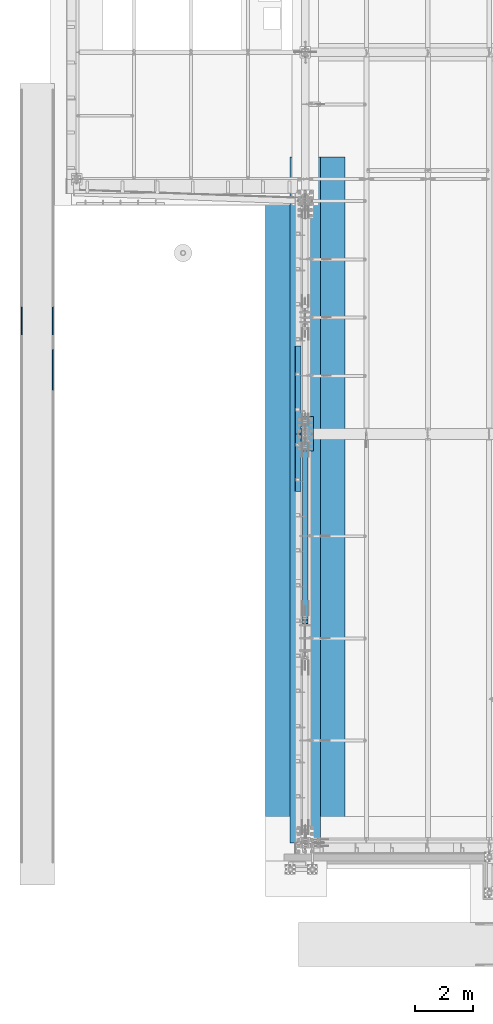
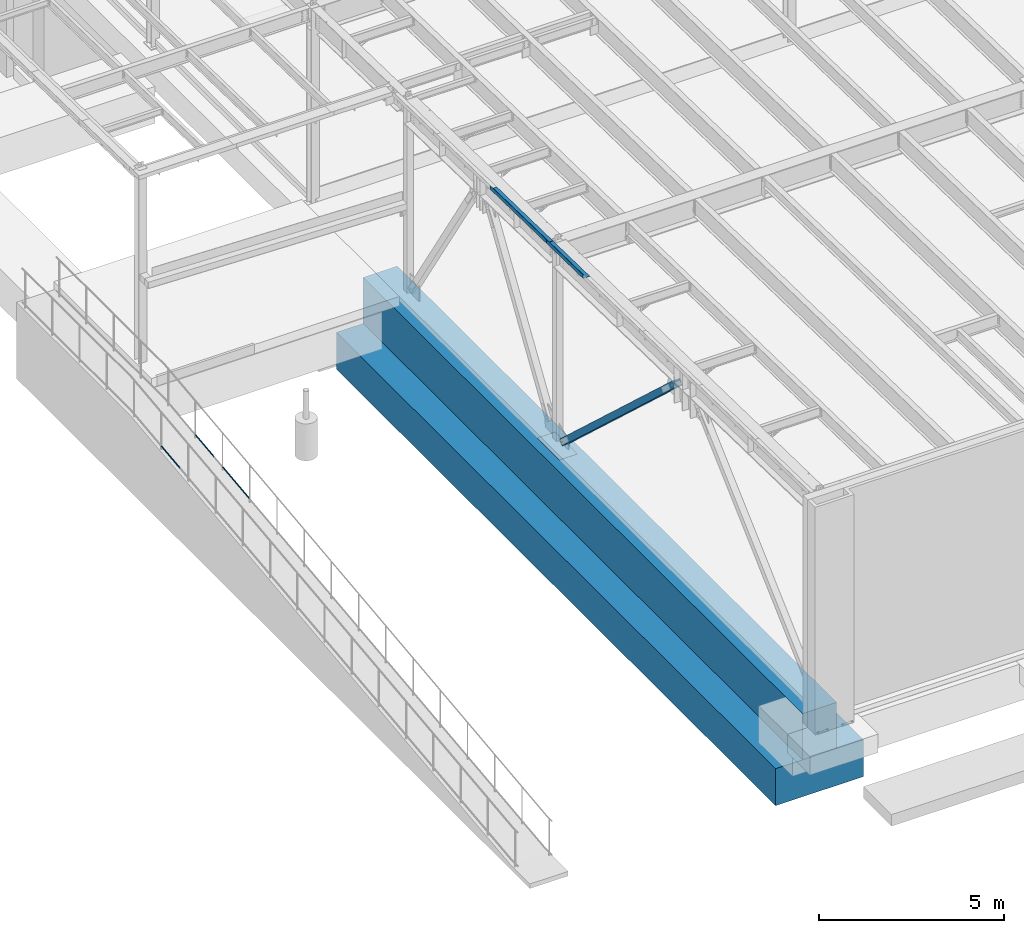
# One storey, part 1043 of 1763: 8 beams, 1 member, 9 elements without a shape of their own.
"""IFC2X3 building model written with IfcOpenShell, lengths in millimetres."""

from ifc_helpers import new_model, si_unit, frame, origin_with_axes, place, context, subcontext, project, spatial, faceted_brep, material, type_object, element, aggregate, save


model = new_model("IFC2X3")

# Units and contexts
model_context = context("Model", 3, precision=1e-05, world=origin_with_axes())
body_context = subcontext(model_context, "Body", "Model", "MODEL_VIEW")
ifc_project = project(units=[si_unit("LENGTHUNIT", "METRE", prefix="MILLI"), si_unit("AREAUNIT", "SQUARE_METRE"), si_unit("VOLUMEUNIT", "CUBIC_METRE"), si_unit("MASSUNIT", "GRAM", prefix="KILO"), si_unit("TIMEUNIT", "SECOND"), si_unit("PLANEANGLEUNIT", "RADIAN"), si_unit("SOLIDANGLEUNIT", "STERADIAN"), si_unit("THERMODYNAMICTEMPERATUREUNIT", "DEGREE_CELSIUS"), si_unit("LUMINOUSINTENSITYUNIT", "LUMEN")], contexts=[model_context])

# Site, building, storey
site_placement = place(None, origin_with_axes())
site = spatial("IfcSite", under=ifc_project, at=site_placement, CompositionType="ELEMENT")
building_placement = place(site_placement, origin_with_axes())
building = spatial("IfcBuilding", under=site, at=building_placement, Name="Undefined", CompositionType="ELEMENT")
storey_placement = place(building_placement, origin_with_axes())
storey = spatial("IfcBuildingStorey", under=building, at=storey_placement, Name="Undefined", CompositionType="ELEMENT", Elevation=0.0)

# Assembly, beam
assembly_1_placement = place(storey_placement, origin_with_axes())
assembly_1 = element("IfcElementAssembly", 1, at=assembly_1_placement, inside=storey, Name="GUARDRAIL", AssemblyPlace="NOTDEFINED", PredefinedType="RIGID_FRAME")
ifc_material_1 = material(Name="STEEL/A513")
beam_type_1 = type_object("IfcBeamType", PredefinedType="NOTDEFINED")
beam_1_placement = place(assembly_1_placement, frame((-97200.6527017878, 3879.70609643673, 5728.63484161927), z_axis=(0.0, -0.114062593029902, 0.993473565260443), x_axis=(0.0, 0.993473565260443, 0.114062593029902)))
beam_1 = element("IfcBeam", 2, at=beam_1_placement, type_object=beam_type_1, material=ifc_material_1, Name="GUARDRAIL", context=body_context, shape_type="Brep", body=[
    faceted_brep([(1007.89445682054, -9.52499999999418, 16.4977839423982), (1007.31680569548, -9.52499999999418, 11.466712380261), (1007.03157048926, -7.68349999999919, 13.3082123802606), (1005.19564016486, 0.0, 15.367000000304), (1005.61851013745, 0.0, 19.0500000003049), (1007.03157048927, 7.68349999999919, 13.3082123802606), (1007.31680569548, 9.52499999999418, 11.466712380261), (1007.89445682054, 9.52499999999418, 16.4977839423982), (1022.60640745074, 19.0500000000029, 3.08318703901023e-10), (1014.11245879407, 16.4977839420899, 9.52500000030705), (1011.92520031513, 16.4977839420899, -9.52499999969496), (1010.6904972139, 13.3082123799541, 7.68350000030568), (1011.8806165228, 15.3669999999984, 3.06499714497477e-10), (1008.92610870756, 13.3082123799541, -7.68349999969541), (1004.6836651308, 9.52499999999418, -11.4667123796526), (1004.10601400574, 9.52499999999418, -16.4977839417907), (1003.975559952, 7.68349999999919, -13.308212379653), (1001.66686315217, 0.0, -15.3669999996973), (1001.24399317958, 0.0, -19.0499999996982), (1004.6836651308, -9.52499999999418, -11.4667123796526), (1004.10601400574, -9.52499999999418, -16.4977839417907), (1003.975559952, -7.68349999999919, -13.308212379653), (1022.60640745069, -19.0500000000029, 3.14685166813433e-10), (1011.92520031513, -16.4977839420899, -9.52499999969496), (1014.11245879407, -16.4977839420899, 9.52500000030705), (1008.92610870756, -13.3082123799541, -7.68349999969541), (1011.88061652279, -15.3669999999984, 3.06499714497477e-10), (1010.69049721389, -13.3082123799541, 7.68350000030568), (0.0, -16.4977839420899, -9.52500000000146), (0.0, -9.52499999999418, -16.4977839420935), (1.45519152283669e-11, 1.81898940354586e-12, -19.0499999999993), (0.0, 9.52499999999418, -16.4977839420935), (0.0, 16.4977839420899, -9.52500000000146), (0.0, 19.0500000000029, 0.0), (0.0, 16.4977839420899, 9.52500000000146), (0.0, 9.52499999999418, 16.4977839420935), (1.45519152283669e-11, 1.81898940354586e-12, 19.0499999999993), (0.0, -9.52499999999418, 16.4977839420935), (0.0, -16.4977839420899, 9.52500000000146), (0.0, -19.0500000000029, 0.0), (3.63797880709171e-12, -13.3082123799541, -7.68349999999737), (3.63797880709171e-12, -7.68349999999919, -13.3082123799522), (3.63797880709171e-12, 0.0, -15.3669999999956), (3.63797880709171e-12, 7.68349999999919, -13.3082123799522), (3.63797880709171e-12, 13.3082123799541, -7.68349999999737), (4.71409293822944e-08, 15.3669999999984, 0.0), (-1.81898940354586e-12, 13.3082123799541, 7.68349999999919), (-3.63797880709171e-12, 7.68349999999919, 13.3082123799531), (-1.81898940354586e-12, 0.0, 15.3669999999966), (-3.63797880709171e-12, -7.68349999999919, 13.3082123799531), (-1.81898940354586e-12, -13.3082123799541, 7.68349999999919), (4.71409293822944e-08, -15.3669999999984, 0.0)], [[[0, 1, 2, 3, 4]], [[4, 3, 5, 6, 7]], [[8, 9, 10]], [[7, 6, 11, 12, 13, 14, 15, 10, 9]], [[16, 17, 18, 15, 14]], [[19, 20, 18, 17, 21]], [[22, 23, 24]], [[24, 23, 20, 19, 25, 26, 27, 1, 0]], [[28, 29, 20, 23]], [[29, 30, 18, 20]], [[30, 31, 15, 18]], [[31, 32, 10, 15]], [[32, 33, 8, 10]], [[33, 34, 9, 8]], [[34, 35, 7, 9]], [[35, 36, 4, 7]], [[36, 37, 0, 4]], [[37, 38, 24, 0]], [[38, 39, 22, 24]], [[39, 28, 23, 22]], [[38, 37, 36, 35, 34, 33, 32, 31, 30, 29, 28, 39], [40, 41, 42, 43, 44, 45, 46, 47, 48, 49, 50, 51]], [[40, 51, 26, 25]], [[21, 41, 40, 25, 19]], [[42, 41, 21, 17]], [[43, 42, 17, 16]], [[44, 43, 16, 14, 13]], [[45, 44, 13, 12]], [[46, 45, 12, 11]], [[5, 47, 46, 11, 6]], [[48, 47, 5, 3]], [[49, 48, 3, 2]], [[50, 49, 2, 1, 27]], [[51, 50, 27, 26]]]),
])
aggregate(assembly_1, [beam_1])

assembly_2_placement = place(storey_placement, origin_with_axes())
assembly_2 = element("IfcElementAssembly", 3, at=assembly_2_placement, inside=storey, Name="GUARDRAIL", AssemblyPlace="NOTDEFINED", PredefinedType="RIGID_FRAME")
beam_2_placement = place(assembly_2_placement, frame((-96133.8527017878, 3879.70609643673, 5728.63484161927), z_axis=(0.0, -0.114062593029902, 0.993473565260443), x_axis=(0.0, 0.993473565260443, 0.114062593029902)))
beam_2 = element("IfcBeam", 4, at=beam_2_placement, type_object=beam_type_1, material=ifc_material_1, Name="GUARDRAIL", context=body_context, shape_type="Brep", body=[
    faceted_brep([(1007.89445682054, -9.52499999999418, 16.4977839423982), (1007.31680569548, -9.52499999999418, 11.466712380261), (1007.03157048926, -7.68349999999919, 13.3082123802606), (1005.19564016486, 0.0, 15.367000000304), (1005.61851013745, 0.0, 19.0500000003049), (1007.03157048927, 7.68349999999919, 13.3082123802606), (1007.31680569548, 9.52499999999418, 11.466712380261), (1007.89445682054, 9.52499999999418, 16.4977839423982), (1022.60640745074, 19.0500000000029, 3.08318703901023e-10), (1014.11245879407, 16.4977839420899, 9.52500000030705), (1011.92520031513, 16.4977839420899, -9.52499999969496), (1010.6904972139, 13.3082123799541, 7.68350000030568), (1011.8806165228, 15.3669999999984, 3.06499714497477e-10), (1008.92610870756, 13.3082123799541, -7.68349999969541), (1004.6836651308, 9.52499999999418, -11.4667123796526), (1004.10601400574, 9.52499999999418, -16.4977839417907), (1003.975559952, 7.68349999999919, -13.308212379653), (1001.66686315217, 0.0, -15.3669999996973), (1001.24399317958, 0.0, -19.0499999996982), (1004.6836651308, -9.52499999999418, -11.4667123796526), (1004.10601400574, -9.52499999999418, -16.4977839417907), (1003.975559952, -7.68349999999919, -13.308212379653), (1022.60640745069, -19.0500000000029, 3.14685166813433e-10), (1011.92520031513, -16.4977839420899, -9.52499999969496), (1014.11245879407, -16.4977839420899, 9.52500000030705), (1008.92610870756, -13.3082123799541, -7.68349999969541), (1011.88061652279, -15.3669999999984, 3.06499714497477e-10), (1010.69049721389, -13.3082123799541, 7.68350000030568), (0.0, -16.4977839420899, -9.52500000000146), (0.0, -9.52499999999418, -16.4977839420935), (1.45519152283669e-11, 1.81898940354586e-12, -19.0499999999993), (0.0, 9.52499999999418, -16.4977839420935), (0.0, 16.4977839420899, -9.52500000000146), (0.0, 19.0500000000029, 0.0), (0.0, 16.4977839420899, 9.52500000000146), (0.0, 9.52499999999418, 16.4977839420935), (1.45519152283669e-11, 1.81898940354586e-12, 19.0499999999993), (0.0, -9.52499999999418, 16.4977839420935), (0.0, -16.4977839420899, 9.52500000000146), (0.0, -19.0500000000029, 0.0), (3.63797880709171e-12, -13.3082123799541, -7.68349999999737), (3.63797880709171e-12, -7.68349999999919, -13.3082123799522), (3.63797880709171e-12, 0.0, -15.3669999999956), (3.63797880709171e-12, 7.68349999999919, -13.3082123799522), (3.63797880709171e-12, 13.3082123799541, -7.68349999999737), (4.71409293822944e-08, 15.3669999999984, 0.0), (-1.81898940354586e-12, 13.3082123799541, 7.68349999999919), (-3.63797880709171e-12, 7.68349999999919, 13.3082123799531), (-1.81898940354586e-12, 0.0, 15.3669999999966), (-3.63797880709171e-12, -7.68349999999919, 13.3082123799531), (-1.81898940354586e-12, -13.3082123799541, 7.68349999999919), (4.71409293822944e-08, -15.3669999999984, 0.0)], [[[0, 1, 2, 3, 4]], [[4, 3, 5, 6, 7]], [[8, 9, 10]], [[7, 6, 11, 12, 13, 14, 15, 10, 9]], [[16, 17, 18, 15, 14]], [[19, 20, 18, 17, 21]], [[22, 23, 24]], [[24, 23, 20, 19, 25, 26, 27, 1, 0]], [[28, 29, 20, 23]], [[29, 30, 18, 20]], [[30, 31, 15, 18]], [[31, 32, 10, 15]], [[32, 33, 8, 10]], [[33, 34, 9, 8]], [[34, 35, 7, 9]], [[35, 36, 4, 7]], [[36, 37, 0, 4]], [[37, 38, 24, 0]], [[38, 39, 22, 24]], [[39, 28, 23, 22]], [[38, 37, 36, 35, 34, 33, 32, 31, 30, 29, 28, 39], [40, 41, 42, 43, 44, 45, 46, 47, 48, 49, 50, 51]], [[40, 51, 26, 25]], [[21, 41, 40, 25, 19]], [[42, 41, 21, 17]], [[43, 42, 17, 16]], [[44, 43, 16, 14, 13]], [[45, 44, 13, 12]], [[46, 45, 12, 11]], [[5, 47, 46, 11, 6]], [[48, 47, 5, 3]], [[49, 48, 3, 2]], [[50, 49, 2, 1, 27]], [[51, 50, 27, 26]]]),
])
aggregate(assembly_2, [beam_2])

assembly_3_placement = place(storey_placement, origin_with_axes())
assembly_3 = element("IfcElementAssembly", 5, at=assembly_3_placement, inside=storey, Name="GUARDRAIL", AssemblyPlace="NOTDEFINED", PredefinedType="RIGID_FRAME")
beam_3_placement = place(assembly_3_placement, frame((-96133.8527017878, 1949.23787684902, 5506.99410694077), z_axis=(0.0, -0.114062593029902, 0.993473565260443), x_axis=(0.0, 0.993473565260443, 0.114062593029902)))
beam_3 = element("IfcBeam", 6, at=beam_3_placement, type_object=beam_type_1, material=ifc_material_1, Name="GUARDRAIL", context=body_context, shape_type="Brep", body=[
    faceted_brep([(1468.16675315117, -9.52499999999418, 16.4977839425374), (1467.58910193435, -9.52499999999418, 11.4667123803993), (1467.30386676072, -7.68349999999919, 13.3082123803997), (1465.46793646955, 0.0, 15.3670000004431), (1465.89080650931, 0.0, 19.0500000004431), (1467.30386676072, 7.68349999999919, 13.3082123803997), (1467.58910193435, 9.52499999999418, 11.4667123803993), (1468.16675315117, 9.52499999999418, 16.4977839425374), (1482.87870351455, 19.0500000000029, 4.47471393272281e-10), (1474.38475501203, 16.4977839420899, 9.52500000044529), (1472.19749618567, 16.4977839420899, -9.52499999955671), (1470.96279339167, 13.3082123799541, 7.68350000044484), (1472.15291256472, 15.3669999999984, 4.43833414465189e-10), (1469.19840460508, 13.3082123799541, -7.68349999955717), (1464.95596095143, 9.52499999999418, -11.4667123795143), (1464.37830973461, 9.52499999999418, -16.4977839416533), (1464.24785573805, 7.68349999999919, -13.3082123795139), (1461.93915889636, 0.0, -15.3669999995591), (1461.5162888566, 0.0, -19.04999999956), (1464.95596095143, -9.52499999999418, -11.4667123795143), (1464.37830973461, -9.52499999999418, -16.4977839416533), (1464.24785573805, -7.68349999999919, -13.3082123795139), (1482.87870351475, -19.0500000000029, 4.2564352042973e-10), (1472.19749618567, -16.4977839420899, -9.52499999955671), (1474.38475501203, -16.4977839420899, 9.52500000044529), (1469.19840460508, -13.3082123799541, -7.68349999955717), (1472.15291256472, -15.3669999999984, 4.43833414465189e-10), (1470.96279339167, -13.3082123799541, 7.68350000044484), (8.49524500772077, -16.4977839420899, -9.52499999999782), (14.7132496349991, -9.52499999999418, -16.4977839420899), (0.00129272617550669, 19.0500000000029, 0.0), (8.49524500772077, 16.4977839420899, -9.52499999999782), (10.6824953029745, 16.4977839420899, 9.52500000000418), (18.5016782752491, 9.52499999999418, 16.4977839421008), (21.3636978799404, 0.0, 19.0500000000075), (14.7132496349991, 9.52499999999418, -16.4977839420899), (16.989197289432, 0.0, -19.0499999999956), (17.4120656798477, 0.0, -15.3669999999956), (15.2908985987647, -9.52499999999418, -11.4667123799509), (15.5761345719984, -7.68349999999919, -13.3082123799513), (15.5761345719984, 7.68349999999919, -13.3082123799513), (15.2908985987647, 9.52499999999418, -11.4667123799509), (11.9172056406151, 13.3082123799541, -7.68349999999737), (10.7270831318519, 15.3669999999984, 4.54747350886464e-12), (13.6815875454467, 13.3082123799541, 7.68350000000555), (17.9240293114835, 9.52499999999418, 11.4667123799618), (18.6321336751216, 7.68349999999919, 13.3082123799622), (20.9408294895247, 0.0, 15.3670000000075), (18.6321336751212, -7.68349999999919, 13.3082123799622), (17.9240293114835, -9.52499999999418, 11.4667123799618), (18.5016782752491, -9.52499999999418, 16.4977839421008), (10.6824953029745, -16.4977839420899, 9.52500000000418), (0.00129272617550669, -19.0500000000029, 0.0), (13.6815875454458, -13.3082123799541, 7.68350000000464), (10.7270831318501, -15.3669999999984, 3.63797880709171e-12), (11.9172056406137, -13.3082123799541, -7.68349999999646)], [[[0, 1, 2, 3, 4]], [[4, 3, 5, 6, 7]], [[8, 9, 10]], [[7, 6, 11, 12, 13, 14, 15, 10, 9]], [[16, 17, 18, 15, 14]], [[19, 20, 18, 17, 21]], [[22, 23, 24]], [[24, 23, 20, 19, 25, 26, 27, 1, 0]], [[28, 29, 20, 23]], [[30, 31, 32]], [[33, 34, 4, 7]], [[32, 33, 7, 9]], [[30, 32, 9, 8]], [[31, 30, 8, 10]], [[35, 31, 10, 15]], [[36, 35, 15, 18]], [[29, 36, 18, 20]], [[37, 36, 29, 38, 39]], [[40, 41, 35, 36, 37]], [[32, 31, 35, 41, 42, 43, 44, 45, 33]], [[33, 45, 46, 47, 34]], [[34, 47, 48, 49, 50]], [[34, 50, 0, 4]], [[50, 51, 24, 0]], [[51, 52, 22, 24]], [[52, 28, 23, 22]], [[51, 28, 52]], [[50, 49, 53, 54, 55, 38, 29, 28, 51]], [[55, 54, 26, 25]], [[21, 39, 38, 55, 25, 19]], [[37, 39, 21, 17]], [[40, 37, 17, 16]], [[42, 41, 40, 16, 14, 13]], [[43, 42, 13, 12]], [[44, 43, 12, 11]], [[5, 46, 45, 44, 11, 6]], [[47, 46, 5, 3]], [[48, 47, 3, 2]], [[53, 49, 48, 2, 1, 27]], [[54, 53, 27, 26]]]),
])
aggregate(assembly_3, [beam_3])

assembly_4_placement = place(storey_placement, origin_with_axes())
assembly_4 = element("IfcElementAssembly", 7, at=assembly_4_placement, inside=storey, Name="STRIP FOOTING", AssemblyPlace="NOTDEFINED", PredefinedType="REINFORCEMENT_UNIT")
ifc_material_2 = material(Name="CONCRETE/5000")
beam_type_2 = type_object("IfcBeamType", PredefinedType="NOTDEFINED")
beam_4_placement = place(assembly_4_placement, frame((-87375.4372736983, -13716.0, 4267.2), z_axis=(0.0, 0.0, 1.0), x_axis=(0.0, 1.0, 0.0)))
beam_4 = element("IfcBeam", 8, at=beam_4_placement, type_object=beam_type_2, material=ifc_material_2, Name="STRIP FOOTING", context=body_context, shape_type="Brep", body=[
    faceted_brep([(0.0, 533.399999999994, -762.0), (0.0, 533.399999999994, 762.0), (23774.4, 533.399999999994, 762.0), (23774.4, 533.399999999994, -762.0), (0.0, -533.399999999994, 762.0), (23774.4, -533.399999999994, 762.0), (0.0, -533.399999999994, -762.0), (23774.4, -533.399999999994, -762.0)], [[[0, 1, 2, 3]], [[1, 4, 5, 2]], [[4, 6, 7, 5]], [[6, 0, 3, 7]], [[5, 7, 3, 2]], [[6, 4, 1, 0]]]),
])
aggregate(assembly_4, [beam_4])

assembly_5_placement = place(storey_placement, origin_with_axes())
assembly_5 = element("IfcElementAssembly", 9, at=assembly_5_placement, inside=storey, Name="BEAM", AssemblyPlace="NOTDEFINED", PredefinedType="RIGID_FRAME")
ifc_material_3 = material(Name="STEEL/A36")
beam_type_3 = type_object("IfcBeamType", PredefinedType="NOTDEFINED")
beam_5_placement = place(assembly_5_placement, frame((-87515.1372736983, 1990.4813218811, 11879.5172039282), z_axis=(0.0, -0.999781542838788, 0.0209013539966307), x_axis=(-1.0, 0.0, 0.0)))
beam_5 = element("IfcBeam", 10, at=beam_5_placement, type_object=beam_type_3, material=ifc_material_3, Name="BENT_PLATE", context=body_context, shape_type="Brep", body=[
    faceted_brep([(0.0, -3.17499999999927, -1523.99999999999), (0.0, -3.17499999999927, 1524.0), (0.0, 3.17499999999927, 1524.0), (0.0, 3.17499999999927, -1523.99999999999), (209.549987792998, 3.174999999379, 1523.99999999984), (209.549987793027, 3.17500000043947, -1523.99999999984), (203.199987793021, -3.17499999956271, -1523.99999999984), (203.199987792992, -3.17500000062137, 1523.99999999984), (209.549987793012, -123.825003589356, 1523.99999999986), (209.549987793012, -123.825003588337, -1523.99999999982), (203.199987793007, -123.825003589356, 1523.99999999986), (203.199987793007, -123.825003588337, -1523.99999999982)], [[[0, 1, 2, 3]], [[3, 2, 4, 5]], [[1, 0, 6, 7]], [[5, 4, 8, 9]], [[4, 2, 1, 7, 10, 8]], [[7, 6, 11, 10]], [[6, 0, 3, 5, 9, 11]], [[10, 11, 9, 8]]]),
])
aggregate(assembly_5, [beam_5])

assembly_6_placement = place(storey_placement, origin_with_axes())
assembly_6 = element("IfcElementAssembly", 11, at=assembly_6_placement, inside=storey, Name="BEAM", AssemblyPlace="NOTDEFINED", PredefinedType="RIGID_FRAME")
beam_type_4 = type_object("IfcBeamType", PredefinedType="NOTDEFINED")
beam_6_placement = place(assembly_6_placement, frame((-87516.7242736983, -534.372399278056, 11932.3016027582), z_axis=(0.0, -0.999781542838788, 0.0209013539966307), x_axis=(-1.0, 0.0, 0.0)))
beam_6 = element("IfcBeam", 12, at=beam_6_placement, type_object=beam_type_4, material=ifc_material_3, Name="BENT_PLATE", context=body_context, shape_type="Brep", body=[
    faceted_brep([(3.63797880709171e-10, -3.17499999965912, -998.766500000008), (-4.07453626394272e-10, -3.17500000034852, 998.766500000008), (-3.63797880709171e-10, 3.1749999996573, 998.766500000008), (4.07453626394272e-10, 3.1750000003467, -998.766500000008), (207.962982177429, 3.17499999825122, 998.766500000088), (207.962982179466, 3.17499999894244, -998.766499999928), (201.61298217946, -3.17500000102154, -998.76649999993), (201.612982177423, -3.17500000171094, 998.766500000086), (207.962982178098, -123.825003589211, 998.766500000169), (207.962982178782, -123.825003589796, -998.766499999847), (201.612982178107, -123.825003589211, 998.766500000167), (201.612982178791, -123.825003589796, -998.76649999985)], [[[0, 1, 2, 3]], [[3, 2, 4, 5]], [[1, 0, 6, 7]], [[5, 4, 8, 9]], [[4, 2, 1, 7, 10, 8]], [[7, 6, 11, 10]], [[6, 0, 3, 5, 9, 11]], [[10, 11, 9, 8]]]),
])
aggregate(assembly_6, [beam_6])

assembly_7_placement = place(storey_placement, origin_with_axes())
assembly_7 = element("IfcElementAssembly", 13, at=assembly_7_placement, inside=storey, Name="STRIP FOOTING", AssemblyPlace="NOTDEFINED", PredefinedType="REINFORCEMENT_UNIT")
beam_type_5 = type_object("IfcBeamType", PredefinedType="NOTDEFINED")
beam_7_placement = place(assembly_7_placement, frame((-87375.4372736983, -13716.0, 2895.6), z_axis=(0.0, 0.0, 1.0), x_axis=(0.0, 1.0, 0.0)))
beam_7 = element("IfcBeam", 14, at=beam_7_placement, type_object=beam_type_5, material=ifc_material_2, Name="STRIP FOOTING", context=body_context, shape_type="Brep", body=[
    faceted_brep([(0.0, 1371.6, -609.6), (0.0, 1371.6, 609.6), (23774.4, 1371.60000000001, 609.6), (23774.4, 1371.60000000001, -609.6), (0.0, -1371.6, 609.6), (23774.4, -1371.60000000001, 609.6), (0.0, -1371.6, -609.6), (23774.4, -1371.60000000001, -609.6)], [[[0, 1, 2, 3]], [[1, 4, 5, 2]], [[4, 6, 7, 5]], [[6, 0, 3, 7]], [[5, 7, 3, 2]], [[6, 4, 1, 0]]]),
])
aggregate(assembly_7, [beam_7])

assembly_8_placement = place(storey_placement, origin_with_axes())
assembly_8 = element("IfcElementAssembly", 15, at=assembly_8_placement, inside=storey, Name="TEMPLATE", AssemblyPlace="NOTDEFINED", PredefinedType="RIGID_FRAME")
beam_type_6 = type_object("IfcBeamType", PredefinedType="NOTDEFINED")
beam_8_placement = place(assembly_8_placement, frame((-87375.4372736983, -126.999999999999, 5083.175), z_axis=(-1.0, 0.0, 0.0), x_axis=(0.0, 1.0, 0.0)))
beam_8 = element("IfcBeam", 16, at=beam_8_placement, type_object=beam_type_6, material=ifc_material_3, Name="TEMPLATE", context=body_context, shape_type="Brep", body=[
    faceted_brep([(0.0, 3.17500000000018, -279.399999999994), (0.0, 3.17500000000018, 279.399999999994), (1193.8, 3.17500000000018, 279.399999999994), (1193.8, 3.17500000000018, -279.399999999994), (0.0, -3.17500000000018, 279.399999999994), (1193.8, -3.17500000000018, 279.399999999994), (0.0, -3.17500000000018, -279.399999999994), (1193.8, -3.17500000000018, -279.399999999994)], [[[0, 1, 2, 3]], [[1, 4, 5, 2]], [[4, 6, 7, 5]], [[6, 0, 3, 7]], [[5, 7, 3, 2]], [[6, 4, 1, 0]]]),
])
aggregate(assembly_8, [beam_8])

# Assembly, member
assembly_9_placement = place(storey_placement, origin_with_axes())
assembly_9 = element("IfcElementAssembly", 17, at=assembly_9_placement, inside=storey, Name="V. BRACE", AssemblyPlace="NOTDEFINED", PredefinedType="RIGID_FRAME")
ifc_material_4 = material()
member_type = type_object("IfcMemberType", Name="HSS8X8X1/2", PredefinedType="NOTDEFINED")
member_placement = place(assembly_9_placement, frame((-87375.4372736983, 457.200000000009, 5130.79999999998), z_axis=(0.0, 0.677746873297468, 0.735295298322726), x_axis=(0.0, -0.735295298322726, 0.677746873297467)))
member = element("IfcMember", 18, at=member_placement, type_object=member_type, material=ifc_material_4, Name="V. BRACE", ObjectType="HSS8X8X1/2", context=body_context, shape_type="Brep", body=[
    faceted_brep([(8851.58529904641, 11.1124999999884, 101.599999997602), (8216.58531363784, 11.1124999999884, 101.599999997773), (8216.58531363785, 11.1124999999884, 88.8999999977718), (8851.58529904641, 11.1124999999884, 88.899999997599), (8212.94025409054, 10.387452576193, 101.599999997774), (8212.94025409055, 10.387452576193, 88.8999999977736), (8209.85012181678, 8.32269220252056, 101.599999997775), (8209.85012181679, 8.32269220252056, 88.8999999977736), (8207.7853614431, 5.23255992875784, 101.599999997774), (8207.78536144311, 5.23255992875784, 88.8999999977755), (8207.06031401931, 1.58750038145809, 101.599999997774), (8207.06031401932, 1.58750038145809, 88.8999999977755), (8207.06031401931, -1.58750076295109, 101.599999997774), (8207.06031401932, -1.58750076295109, 88.8999999977755), (8207.7853614431, -5.23256031025085, 101.599999997774), (8207.78536144311, -5.23256031025085, 88.8999999977755), (8209.85012181678, -8.32269258401357, 101.599999997775), (8209.85012181679, -8.32269258401357, 88.8999999977736), (8212.94025409054, -10.387452957686, 101.599999997774), (8212.94025409055, -10.387452957686, 88.8999999977736), (8216.58531363784, -11.1125003814814, 101.599999997773), (8216.58531363785, -11.1125003814814, 88.8999999977718), (8851.58529904641, -11.1125003814814, 101.599999997602), (8851.58529904641, -11.1125003814814, 88.899999997599), (8851.58529904644, 11.1124999999884, -88.9000000024148), (8216.58531363792, 11.1124999999884, -88.9000000022429), (8216.58531363793, 11.1124999999884, -101.600000002245), (8851.58529904644, 11.1124999999884, -101.600000002417), (8212.94025409063, 10.387452576193, -88.9000000022425), (8212.94025409064, 10.387452576193, -101.600000002241), (8209.85012181686, 8.32269220252056, -88.9000000022397), (8209.85012181687, 8.32269220252056, -101.600000002242), (8207.78536144319, 5.23255992875784, -88.9000000022411), (8207.78536144319, 5.23255992875784, -101.600000002241), (8207.06031401939, 1.58750038145809, -88.9000000022411), (8207.0603140194, 1.58750038145809, -101.60000000224), (8207.06031401939, -1.58750076295109, -88.9000000022411), (8207.0603140194, -1.58750076295109, -101.60000000224), (8207.78536144319, -5.23256031025085, -88.9000000022411), (8207.78536144319, -5.23256031025085, -101.600000002241), (8209.85012181686, -8.32269258401357, -88.9000000022397), (8209.85012181687, -8.32269258401357, -101.600000002242), (8212.94025409063, -10.387452957686, -88.9000000022425), (8212.94025409064, -10.387452957686, -101.600000002241), (8216.58531363792, -11.1125003814814, -88.9000000022429), (8216.58531363793, -11.1125003814814, -101.600000002245), (8851.58529904644, -11.1125003814814, -88.9000000024148), (8851.58529904644, -11.1125003814814, -101.600000002417), (484.966364630503, 88.8999999999942, 88.9000000001724), (484.966364630512, 88.8999999999942, -88.8999999999123), (8851.58529904644, 88.8999999999942, -88.9000000024148), (8851.58529904641, 88.8999999999942, 88.899999997599), (8851.58529904641, -88.8999999999942, 88.899999997599), (484.966364630503, -88.8999999999942, 88.9000000001724), (484.966364630503, -14.2874999999913, 88.9000000001724), (713.566372206521, -14.2874999999913, 88.9000000002343), (718.426451724556, -13.3207700774074, 88.9000000002343), (722.546628192698, -10.5677561769262, 88.9000000002343), (725.29964209317, -6.44757970876526, 88.9000000002361), (726.266372015754, -1.58750019072613, 88.9000000002379), (726.266372015754, 1.58750095368305, 88.9000000002379), (725.29964209317, 6.44758047172218, 88.9000000002361), (722.546628192698, 10.5677569398831, 88.9000000002343), (718.426451724556, 13.3207708403643, 88.9000000002343), (713.566372206521, 14.2875007629482, 88.9000000002343), (484.966364630503, 14.2875007629482, 88.9000000001724), (484.966364630512, -88.8999999999942, -88.8999999999123), (8851.58529904644, -88.8999999999942, -88.9000000024148), (484.966364630512, 14.2875007629482, -88.8999999999123), (713.566372206587, 14.2875007629482, -88.8999999998487), (718.426451724621, 13.3207708403643, -88.8999999998487), (722.546628192766, 10.5677569398831, -88.8999999998487), (725.299642093236, 6.44758047172218, -88.8999999998468), (726.266372015823, 1.58750095368305, -88.8999999998487), (726.266372015823, -1.58750019072613, -88.8999999998487), (725.299642093236, -6.44757970876526, -88.8999999998468), (722.546628192766, -10.5677561769262, -88.8999999998487), (718.426451724621, -13.3207700774074, -88.8999999998487), (713.566372206587, -14.2874999999913, -88.8999999998487), (484.966364630512, -14.2874999999913, -88.8999999999123), (484.966364630512, 14.2875007629482, -101.599999999917), (713.566372206593, 14.2875007629482, -101.599999999857), (718.426451724627, 13.3207708403643, -101.599999999855), (722.546628192771, 10.5677569398831, -101.599999999855), (725.299642093241, 6.44758047172218, -101.599999999853), (726.266372015826, 1.58750095368305, -101.599999999853), (726.266372015826, -1.58750019072613, -101.599999999853), (725.299642093241, -6.44757970876526, -101.599999999853), (722.546628192771, -10.5677561769262, -101.599999999855), (718.426451724627, -13.3207700774074, -101.599999999855), (713.566372206593, -14.2874999999913, -101.599999999857), (484.966364630512, -14.2874999999913, -101.599999999917), (484.966364630512, -101.600000000006, -101.599999999917), (484.966364630501, -101.600000000006, 101.600000000179), (484.966364630501, -14.2874999999913, 101.600000000179), (713.566372206516, -14.2874999999913, 101.600000000239), (718.426451724552, -13.3207700774074, 101.60000000024), (722.546628192694, -10.5677561769262, 101.600000000242), (725.299642093165, -6.44757970876526, 101.600000000242), (726.266372015751, -1.58750019072613, 101.600000000242), (726.266372015751, 1.58750095368305, 101.600000000242), (725.299642093165, 6.44758047172218, 101.600000000242), (722.546628192694, 10.5677569398831, 101.600000000242), (718.426451724552, 13.3207708403643, 101.60000000024), (713.566372206516, 14.2875007629482, 101.600000000239), (484.966364630501, 14.2875007629482, 101.600000000179), (484.966364630501, 101.600000000006, 101.600000000179), (484.966364630512, 101.600000000006, -101.599999999917), (8851.58529904641, 101.600000000006, 101.599999997602), (8851.58529904644, 101.600000000006, -101.600000002417), (8851.58529904644, -101.600000000006, -101.600000002417), (8851.58529904641, -101.600000000006, 101.599999997602)], [[[0, 1, 2, 3]], [[4, 5, 2, 1]], [[6, 7, 5, 4]], [[8, 9, 7, 6]], [[10, 11, 9, 8]], [[12, 13, 11, 10]], [[14, 15, 13, 12]], [[16, 17, 15, 14]], [[18, 19, 17, 16]], [[20, 21, 19, 18]], [[22, 23, 21, 20]], [[24, 25, 26, 27]], [[28, 29, 26, 25]], [[30, 31, 29, 28]], [[32, 33, 31, 30]], [[34, 35, 33, 32]], [[36, 37, 35, 34]], [[38, 39, 37, 36]], [[40, 41, 39, 38]], [[42, 43, 41, 40]], [[44, 45, 43, 42]], [[46, 47, 45, 44]], [[48, 49, 50, 51]], [[52, 53, 54, 55, 56, 57, 58, 59, 60, 61, 62, 63, 64, 65, 48, 51, 3, 2, 5, 7, 9, 11, 13, 15, 17, 19, 21, 23]], [[66, 53, 52, 67]], [[42, 40, 38, 36, 34, 32, 30, 28, 25, 24, 50, 49, 68, 69, 70, 71, 72, 73, 74, 75, 76, 77, 78, 79, 66, 67, 46, 44]], [[68, 80, 81, 69]], [[69, 81, 82, 70]], [[70, 82, 83, 71]], [[71, 83, 84, 72]], [[72, 84, 85, 73]], [[73, 85, 86, 74]], [[74, 86, 87, 75]], [[75, 87, 88, 76]], [[76, 88, 89, 77]], [[77, 89, 90, 78]], [[78, 90, 91, 79]], [[53, 66, 79, 91, 92, 93, 94, 54]], [[95, 55, 54, 94]], [[96, 56, 55, 95]], [[97, 57, 56, 96]], [[98, 58, 57, 97]], [[99, 59, 58, 98]], [[100, 60, 59, 99]], [[101, 61, 60, 100]], [[102, 62, 61, 101]], [[103, 63, 62, 102]], [[104, 64, 63, 103]], [[105, 65, 64, 104]], [[106, 107, 80, 68, 49, 48, 65, 105]], [[107, 106, 108, 109]], [[51, 50, 24, 27, 109, 108, 0, 3]], [[110, 92, 91, 90, 89, 88, 87, 86, 85, 84, 83, 82, 81, 80, 107, 109, 27, 26, 29, 31, 33, 35, 37, 39, 41, 43, 45, 47]], [[93, 92, 110, 111]], [[18, 16, 14, 12, 10, 8, 6, 4, 1, 0, 108, 106, 105, 104, 103, 102, 101, 100, 99, 98, 97, 96, 95, 94, 93, 111, 22, 20]], [[111, 110, 47, 46, 67, 52, 23, 22]]]),
])
aggregate(assembly_9, [member])

save(model, "model.ifc")
